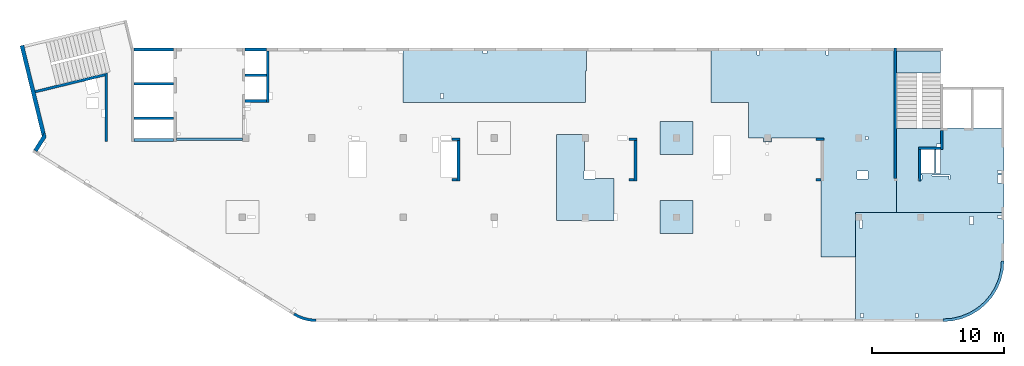
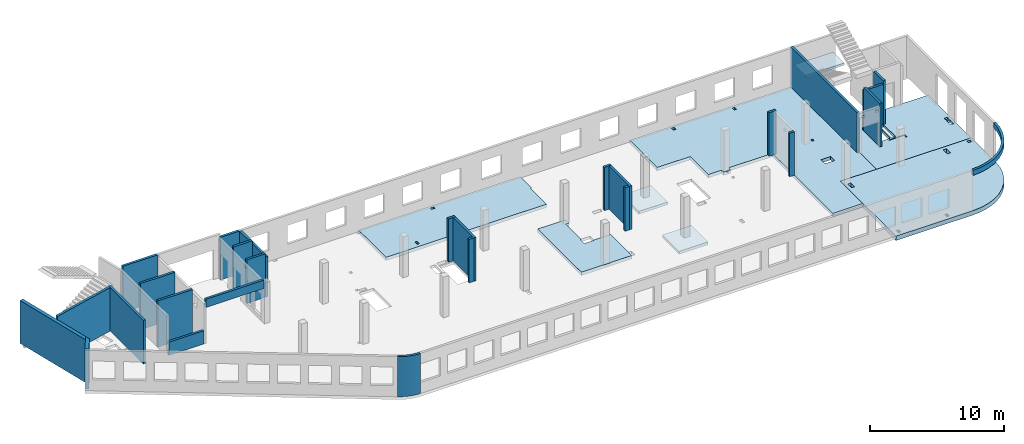
# One storey, part 2 of 6: 27 walls, 8 slabs.
"""IFC4 building model written with IfcOpenShell, lengths in millimetres."""

from ifc_helpers import new_model, entity, si_unit, converted_unit, derived_unit, direction, frame, origin, place, context, subcontext, project, spatial, indexed_curve, outline, extrude, material, type_object, element, save


model = new_model("IFC4")

# Units and contexts
model_context = context("Model", 3, precision=0.01, world=origin(), true_north=direction((6.12303176911189e-17, 1.0)))
plan_context = context("Plan", 3, precision=0.01, world=origin(), true_north=direction((6.12303176911189e-17, 1.0)))
body_context = subcontext(model_context, "Body", "Model", "MODEL_VIEW")
ifc_project = project(units=[si_unit("LENGTHUNIT", "METRE", prefix="MILLI"), si_unit("AREAUNIT", "SQUARE_METRE"), si_unit("VOLUMEUNIT", "CUBIC_METRE"), converted_unit("PLANEANGLEUNIT", "DEGREE", entity("IfcRatioMeasure", 0.0174532925199433), si_unit("PLANEANGLEUNIT", "RADIAN"), dimensions=[0, 0, 0, 0, 0, 0, 0]), si_unit("MASSUNIT", "GRAM", prefix="KILO"), derived_unit("MASSDENSITYUNIT", [(si_unit("MASSUNIT", "GRAM", prefix="KILO"), 1), (si_unit("LENGTHUNIT", "METRE"), -3)]), derived_unit("MOMENTOFINERTIAUNIT", [(si_unit("LENGTHUNIT", "METRE"), 4)]), si_unit("TIMEUNIT", "SECOND"), si_unit("FREQUENCYUNIT", "HERTZ"), si_unit("THERMODYNAMICTEMPERATUREUNIT", "DEGREE_CELSIUS"), derived_unit("THERMALTRANSMITTANCEUNIT", [(si_unit("MASSUNIT", "GRAM", prefix="KILO"), 1), (si_unit("THERMODYNAMICTEMPERATUREUNIT", "KELVIN"), -1), (si_unit("TIMEUNIT", "SECOND"), -3)]), derived_unit("VOLUMETRICFLOWRATEUNIT", [(si_unit("LENGTHUNIT", "METRE"), 3), (si_unit("TIMEUNIT", "SECOND"), -1)]), derived_unit("MASSFLOWRATEUNIT", [(si_unit("MASSUNIT", "GRAM", prefix="KILO"), 1), (si_unit("TIMEUNIT", "SECOND"), -1)]), derived_unit("ROTATIONALFREQUENCYUNIT", [(si_unit("TIMEUNIT", "SECOND"), -1)]), si_unit("ELECTRICCURRENTUNIT", "AMPERE"), si_unit("ELECTRICVOLTAGEUNIT", "VOLT"), si_unit("POWERUNIT", "WATT"), si_unit("FORCEUNIT", "NEWTON", prefix="KILO"), si_unit("ILLUMINANCEUNIT", "LUX"), si_unit("LUMINOUSFLUXUNIT", "LUMEN"), si_unit("LUMINOUSINTENSITYUNIT", "CANDELA"), derived_unit("USERDEFINED", [(si_unit("MASSUNIT", "GRAM", prefix="KILO"), -1), (si_unit("LENGTHUNIT", "METRE"), -2), (si_unit("TIMEUNIT", "SECOND"), 3), (si_unit("LUMINOUSFLUXUNIT", "LUMEN"), 1)]), derived_unit("LINEARVELOCITYUNIT", [(si_unit("LENGTHUNIT", "METRE"), 1), (si_unit("TIMEUNIT", "SECOND"), -1)]), si_unit("PRESSUREUNIT", "PASCAL"), derived_unit("USERDEFINED", [(si_unit("LENGTHUNIT", "METRE"), -2), (si_unit("MASSUNIT", "GRAM", prefix="KILO"), 1), (si_unit("TIMEUNIT", "SECOND"), -2)]), derived_unit("LINEARFORCEUNIT", [(si_unit("MASSUNIT", "GRAM", prefix="KILO"), 1), (si_unit("LENGTHUNIT", "METRE"), 1), (si_unit("TIMEUNIT", "SECOND"), -2), (si_unit("LENGTHUNIT", "METRE"), -1)]), derived_unit("PLANARFORCEUNIT", [(si_unit("MASSUNIT", "GRAM", prefix="KILO"), 1), (si_unit("LENGTHUNIT", "METRE"), 1), (si_unit("TIMEUNIT", "SECOND"), -2), (si_unit("LENGTHUNIT", "METRE"), -2)])], contexts=[model_context, plan_context])

# Site, building, storey
site_placement = place(None, origin())
site = spatial("IfcSite", under=ifc_project, at=site_placement, CompositionType="ELEMENT")
building_placement = place(site_placement, origin())
building = spatial("IfcBuilding", under=site, at=building_placement, CompositionType="ELEMENT")
storey_placement = place(building_placement, frame((0.0, 0.0, 8100.0)))
storey = spatial("IfcBuildingStorey", under=building, at=storey_placement, Name="03", CompositionType="ELEMENT", Elevation=8100.0)

# Slabs
ifc_material = material()
slab_type_1 = type_object("IfcSlabType", Name=":ADSK_ 25_300", PredefinedType="FLOOR", material=ifc_material)
placement = place(storey_placement, origin())
element("IfcSlab", 1, at=placement, inside=storey, type_object=slab_type_1, material=ifc_material, Name=":ADSK_ 25_300", ObjectType=":ADSK_ 25_300", PredefinedType="FLOOR", context=body_context, shape_type="SweptSolid", body=[
    extrude(outline(indexed_curve([(-6774.16666666654, -2197.29156649669), (-6774.16666666654, -2497.29156649652), (-6774.16666666654, -6097.29156649676), (-6774.16666666654, -6297.29156649672), (7265.83333333328, -6297.29156649672), (7265.83333333328, -6097.29156649676), (7265.83333333328, -3412.29188617987), (7265.83333333328, -2497.29156649651), (7265.83333333328, -527.291566496528), (7265.83333333329, 6152.70843350346), (4155.83333333329, 6152.70843350346), (4155.83333333329, 9502.70843350343), (1565.83333333329, 9502.70843350343), (1565.83333333328, 502.70843350344), (-2194.16666666669, 502.708433503438), (-2194.16666666669, 802.708433503275), (-2419.16666666676, 802.708433503273), (-2419.16666666676, 792.707391304612), (-2619.16666666675, 792.707391304612), (-2619.16666666675, 802.708433503274), (-2794.16666666671, 802.708433503274), (-2794.16666666671, 502.708433503384), (-3944.16666666658, 502.708433503383), (-3944.16666666658, -2197.29156649669), (-6774.16666666654, -2197.29156649669)], self_intersect=False), holes=[indexed_curve([(5105.83333333324, 402.707391304573), (4905.83333333325, 402.707391304574), (4905.83333333325, 602.707391304598), (5105.83333333324, 602.707391304597), (5105.83333333324, 402.707391304573)], self_intersect=False), indexed_curve([(4290.83333333324, 3017.70739130459), (4290.83333333324, 3617.70739130459), (5120.83333333326, 3617.70739130459), (5120.83333333326, 3017.70739130459), (4290.83333333324, 3017.70739130459)], self_intersect=False), indexed_curve([(2115.83333333324, -5797.29260869539), (2115.83333333324, -6097.29220586319), (1915.83333333322, -6097.29220586319), (1915.83333333322, -5797.29260869539), (2115.83333333324, -5797.29260869539)], self_intersect=False), indexed_curve([(-3094.16666666675, -5797.29260869538), (-3094.16666666675, -6097.29220586318), (-3294.16666666678, -6097.29220586318), (-3294.16666666678, -5797.29260869538), (-3094.16666666675, -5797.29260869538)], self_intersect=False)]), frame((58164.17, 14202.71, -450.0), z_axis=(0.0, 0.0, -1.0), x_axis=(1.0, 0.0, 0.0)), (0.0, 0.0, -1.0), 300.0),
])
slab_type_2 = type_object("IfcSlabType", Name=":ADSK_ 25_250", PredefinedType="FLOOR", material=ifc_material)
element("IfcSlab", 2, at=placement, inside=storey, type_object=slab_type_2, material=ifc_material, Name=":ADSK_ 25_250", ObjectType=":ADSK_ 25_250", PredefinedType="FLOOR", context=body_context, shape_type="SweptSolid", body=[
    extrude(outline(indexed_curve([(-3285.0, -2417.49999999997), (-3085.00000000002, -2417.49999999997), (1515.00000000001, -2417.49999999998), (1515.00000000001, -2377.50000000001), (4854.99999999999, -2377.50000000002), (4855.0, 4002.49999999997), (-3085.0, 4002.49999999999), (-3284.99999999999, 4002.49999999999), (-3285.0, -2417.49999999997)], self_intersect=False), holes=[indexed_curve([(-3084.99918212893, 1767.49895780109), (-2784.99999999999, 1767.49895780109), (-2784.99999999999, 1167.50000000054), (-3084.99918212893, 1167.50000000054), (-3084.99918212893, 1767.49895780109)], self_intersect=False), indexed_curve([(-3084.99918212893, 1002.49895780108), (-2784.99999999999, 1002.49895780108), (-2784.99999999999, 802.498957801087), (-3084.99918212893, 802.498957801087), (-3084.99918212893, 1002.49895780108)], self_intersect=False), indexed_curve([(1514.99999999996, -1177.50104219891), (1514.99999999996, -977.499999999505), (1815.00000000004, -977.499999999505), (1815.00000000004, -1177.50104219891), (1514.99999999996, -1177.50104219891)], self_intersect=False), indexed_curve([(3005.00000000001, 1487.49895780109), (3005.00000000001, 1147.49895780109), (2925.00000000003, 1147.49895780109), (2925.00000000003, 1487.49895780109), (3005.00000000001, 1487.49895780109)], self_intersect=False), indexed_curve([(3004.99999999993, 1027.49895780109), (3004.99999999993, -777.499999999511), (1965.00000000004, -777.499999999511), (1965.00000000004, 1027.49895780109), (3004.99999999993, 1027.49895780109)], self_intersect=False), indexed_curve([(1515.00000000004, 1027.49895780109), (1845.00000000003, 1027.49895780109), (1845.00000000003, -777.499999999505), (1515.00000000004, -777.499999999505), (1515.00000000004, 1027.49895780109)], self_intersect=False), indexed_curve([(885.000000000007, 1227.49895780108), (2185.00000000002, 1227.49895780108), (2185.00000000002, 1167.49895780109), (805.000000000025, 1167.49895780109), (805.000000000025, 1487.49895780109), (885.000000000007, 1487.49895780109), (885.000000000007, 1227.49895780108)], self_intersect=False)]), frame((70285.0, 12052.5, -400.0), z_axis=(0.0, 0.0, 1.0), x_axis=(-1.0, 0.0, 0.0)), (0.0, 0.0, 1.0), 249.999999999999),
])
slab_type_3 = type_object("IfcSlabType", Name=":ADSK_ 25_300", PredefinedType="FLOOR", material=ifc_material)
element("IfcSlab", 3, at=placement, inside=storey, type_object=slab_type_3, material=ifc_material, Name=":ADSK_ 25_300", ObjectType=":ADSK_ 25_300", PredefinedType="FLOOR", context=body_context, shape_type="SweptSolid", body=[
    extrude(outline(indexed_curve([(-1983.99983184359, -6920.0), (-1784.00047120995, -6920.0), (-1584.00087404217, -6920.0), (1816.00016815662, -6920.00000000001), (2116.00016815641, -6920.00000000001), (2116.00016815645, 6880.0), (1816.00016815666, 6880.0), (-263.999831843444, 6880.0), (-263.999831843444, 6980.0), (-1983.99983184354, 6980.0), (-1983.99983184359, -6920.0)], self_intersect=False), holes=[indexed_curve([(1455.99912595783, -3870.00000000006), (1815.99912595782, -3870.00000000006), (1815.99912595782, -4070.00000000005), (1455.99912595783, -4070.00000000005), (1455.99912595783, -3870.00000000006)], self_intersect=False), indexed_curve([(-1584.00087404217, -570.000000000044), (-1584.00087404217, -870.000000000045), (-1783.9998318435, -870.000000000045), (-1783.9998318435, -570.000000000044), (-1584.00087404217, -570.000000000044)], self_intersect=False)]), frame((34990.0, 18516.0, -450.0), z_axis=(0.0, 0.0, 1.0), x_axis=(0.0, -1.0, 0.0)), (0.0, 0.0, 1.0), 300.0),
])
slab_type_4 = type_object("IfcSlabType", Name=":ADSK_ 25_400", PredefinedType="FLOOR", material=ifc_material)
element("IfcSlab", 4, at=placement, inside=storey, type_object=slab_type_4, material=ifc_material, Name=":ADSK_ 25_400", ObjectType=":ADSK_ 25_400", PredefinedType="FLOOR", context=body_context, shape_type="SweptSolid", body=[
    extrude(outline(indexed_curve([(-3587.4999999999, -5067.08333333327), (-3287.49999999989, -5067.08333333327), (-512.500000000005, -5067.08333333327), (4462.49999999999, -5067.08333333328), (4662.49999999995, -5067.08333333328), (4662.49999999996, -4667.08333333327), (4662.49999999998, 1582.91666666618), (4605.86636673761, 2302.5152058513), (4437.35997495767, 3004.39484079108), (4161.13001126643, 3671.27296546831), (3783.97817412466, 4286.72882721185), (3315.19119345797, 4835.60786012465), (2766.31216054517, 5304.39484079136), (2150.85629880164, 5681.54667793313), (1483.97817412441, 5957.77664162439), (782.098539184638, 6126.28303340435), (62.4999999994953, 6182.91666666672), (-362.499999999969, 6182.91666666672), (-3587.49999999986, 6182.91666666673), (-3587.49999999986, 5982.91666666674), (-3587.49999999987, 3887.91666666673), (-3587.4999999999, -5067.08333333327)], self_intersect=False), holes=[indexed_curve([(4062.49895780123, -4467.08333333328), (4362.49895780123, -4467.08333333328), (4362.49895780123, -4666.87317969451), (4062.49895780123, -4666.87317969451), (4062.49895780123, -4467.08333333328)], self_intersect=False), indexed_curve([(4062.49895780123, -317.083333333292), (4362.49895780123, -317.083333333292), (4362.49895780123, -517.083333333281), (4062.49895780123, -517.083333333281), (4062.49895780123, -317.083333333292)], self_intersect=False), indexed_curve([(-2677.50104219876, 3887.91666666671), (-2677.50104219876, 3587.9166666667), (-3287.50104219876, 3587.9166666667), (-3287.50104219876, 3887.91666666671), (-2677.50104219876, 3887.91666666671)], self_intersect=False), indexed_curve([(-3362.50104219877, 5982.91584879566), (-3162.50104219878, 5982.91584879566), (-3162.50104219878, 5682.91666666673), (-3362.50104219877, 5682.91666666673), (-3362.50104219877, 5982.91584879566)], self_intersect=False), indexed_curve([(-2427.50104219875, -4767.08333333328), (-2987.49999999956, -4767.08333333328), (-2987.49999999956, -4567.08333333327), (-2987.49999999956, -4517.08333333327), (-2427.50104219875, -4517.08333333327), (-2427.50104219875, -4767.08333333328)], self_intersect=False)]), frame((67387.08, 4462.5, -550.0), z_axis=(0.0, 0.0, 1.0), x_axis=(0.0, -1.0, 0.0)), (0.0, 0.0, 1.0), 400.0),
])
slab_type_5 = type_object("IfcSlabType", Name=":ADSK_ 25_300", PredefinedType="FLOOR", material=ifc_material)
element("IfcSlab", 5, at=placement, inside=storey, type_object=slab_type_5, material=ifc_material, Name=":ADSK_ 25_300", ObjectType=":ADSK_ 25_300", PredefinedType="FLOOR", context=body_context, shape_type="SweptSolid", body=[
    extrude(outline(indexed_curve([(-3757.49999999989, -2308.33333333336), (2742.5000000001, -2308.33333333336), (2742.5000000001, 116.666666666688), (2242.49999999951, 116.666666666689), (2242.49999999951, -183.333333333312), (-22.4999999999042, -183.333333333309), (-22.4999999999043, -248.333333333355), (-622.499999999904, -248.333333333354), (-622.499999999905, 581.666666666648), (-582.499999999908, 581.666666666648), (-582.49999999991, 2041.66666666668), (-3757.4999999999, 2041.66666666669), (-3757.49999999989, -2308.33333333336)], self_intersect=False)), frame((42003.33, 11207.5, -150.0), z_axis=(0.0, 0.0, -1.0), x_axis=(0.0, 1.0, 0.0)), (0.0, 0.0, 1.0), 300.0),
])
slab_type_6 = type_object("IfcSlabType", Name=":ADSK_ 25_250", PredefinedType="FLOOR", material=ifc_material)
element("IfcSlab", 6, at=placement, inside=storey, type_object=slab_type_6, material=ifc_material, Name=":ADSK_ 25_250", ObjectType=":ADSK_ 25_250", PredefinedType="FLOOR", context=body_context, shape_type="SweptSolid", body=[
    extrude(outline(indexed_curve([(-1250.0, -1249.99999999999), (1250.0, -1249.99999999999), (1250.0, 1250.0), (-1250.0, 1250.0), (-1250.0, -1249.99999999999)], self_intersect=False)), frame((48770.0, 7700.0, -400.0), z_axis=(0.0, 0.0, -1.0), x_axis=(0.0, 1.0, 0.0)), (0.0, 0.0, 1.0), 250.000000000001),
])
slab_type_7 = type_object("IfcSlabType", Name=":ADSK_ 25_250", PredefinedType="FLOOR", material=ifc_material)
element("IfcSlab", 7, at=placement, inside=storey, type_object=slab_type_7, material=ifc_material, Name=":ADSK_ 25_250", ObjectType=":ADSK_ 25_250", PredefinedType="FLOOR", context=body_context, shape_type="SweptSolid", body=[
    extrude(outline(indexed_curve([(-1250.0, -1250.0), (1250.0, -1250.0), (1250.0, 1249.99999999999), (-1250.0, 1249.99999999999), (-1250.0, -1250.0)], self_intersect=False)), frame((48770.0, 13700.0, -400.0), z_axis=(0.0, 0.0, -1.0), x_axis=(0.0, 1.0, 0.0)), (0.0, 0.0, 1.0), 250.000000000001),
])
slab_type_8 = type_object("IfcSlabType", Name=":ADSK_ 25_200", PredefinedType="FLOOR", material=ifc_material)
element("IfcSlab", 8, at=placement, inside=storey, type_object=slab_type_8, material=ifc_material, Name=":ADSK_ 25_200", ObjectType=":ADSK_ 25_200", PredefinedType="FLOOR", context=body_context, shape_type="SweptSolid", body=[
    extrude(outline(indexed_curve([(-834.999999999999, -1670.00000000001), (835.000000000001, -1670.00000000001), (835.000000000001, 1670.00000000002), (-834.999999999999, 1670.00000000002), (-834.999999999999, -1670.00000000001)], self_intersect=False)), frame((67100.0, 19465.0, 1920.0), z_axis=(0.0, 0.0, -1.0), x_axis=(0.0, 1.0, 0.0)), (0.0, 0.0, 1.0), 200.0),
])

# Walls
wall_type_1 = type_object("IfcWallType", Name=":ADSK_ 25_200", PredefinedType="STANDARD")
wall_1_placement = place(storey_placement, frame((68870.0, 14270.0, -150.0), z_axis=(0.0, 0.0, 1.0), x_axis=(0.0, -1.0, 0.0)))
element("IfcWall", 9, at=wall_1_placement, inside=storey, type_object=wall_type_1, material=ifc_material, Name=":ADSK_ 25_200", ObjectType=":ADSK_ 25_200", PredefinedType="NOTDEFINED", context=body_context, shape_type="SweptSolid", body=[
    extrude(outline(indexed_curve([(1439.99999999999, 100.000000000003), (0.0, 100.000000000003), (0.0, -100.000000000003), (1439.99999999999, -100.000000000003), (1439.99999999999, 100.000000000003)], self_intersect=False)), origin(), (0.0, 0.0, 1.0), 3950.0),
])
wall_2_placement = place(storey_placement, frame((68770.0, 12930.0, -150.0), z_axis=(0.0, 0.0, 1.0), x_axis=(-1.0, 0.0, 0.0)))
element("IfcWall", 10, at=wall_2_placement, inside=storey, type_object=wall_type_1, material=ifc_material, Name=":ADSK_ 25_200", ObjectType=":ADSK_ 25_200", PredefinedType="NOTDEFINED", context=body_context, shape_type="SweptSolid", body=[
    extrude(outline(indexed_curve([(1689.99999999997, 99.9999999999989), (-3.84449868389964e-13, 99.9999999999989), (3.84449868389964e-13, -99.9999999999989), (1689.99999999997, -99.9999999999989), (1689.99999999997, 99.9999999999989)], self_intersect=False)), origin(), (0.0, 0.0, 1.0), 3650.0),
])
wall_3_placement = place(storey_placement, frame((67180.0, 12830.0, -150.0), z_axis=(0.0, 0.0, 1.0), x_axis=(0.0, -1.0, 0.0)))
element("IfcWall", 11, at=wall_3_placement, inside=storey, type_object=wall_type_1, material=ifc_material, Name=":ADSK_ 25_200", ObjectType=":ADSK_ 25_200", PredefinedType="NOTDEFINED", context=body_context, shape_type="SweptSolid", body=[
    extrude(outline(indexed_curve([(2404.99999999995, 100.000000000003), (0.0, 100.000000000003), (0.0, -100.000000000003), (2404.99999999995, -100.000000000003), (2404.99999999995, 100.000000000003)], self_intersect=False)), origin(), (0.0, 0.0, 1.0), 3950.0),
])
wall_4_placement = place(storey_placement, frame((65330.0, 10625.0, -150.0), z_axis=(0.0, 0.0, 1.0), x_axis=(0.0, 1.0, 0.0)))
element("IfcWall", 12, at=wall_4_placement, inside=storey, type_object=wall_type_1, material=ifc_material, Name=":ADSK_ 25_200", ObjectType=":ADSK_ 25_200", PredefinedType="NOTDEFINED", context=body_context, shape_type="SweptSolid", body=[
    extrude(outline(indexed_curve([(9875.00063936713, 100.000000000003), (-1.71685740578866e-13, 100.000000000003), (1.71685740578866e-13, -100.000000000003), (9875.00063936713, -100.000000000004), (9875.00063936713, 100.000000000003)], self_intersect=False)), origin(), (0.0, 0.0, 1.0), 3650.0),
])
wall_5_placement = place(storey_placement, frame((68970.0, -100.0, 3050.0)))
element("IfcWall", 13, at=wall_5_placement, inside=storey, type_object=wall_type_1, material=ifc_material, Name=":ADSK_ 25_200", ObjectType=":ADSK_ 25_200", PredefinedType="NOTDEFINED", context=body_context, shape_type="SweptSolid", body=[
    extrude(outline(indexed_curve([(4399.99918212903, 4499.99918212888), (4345.82789081698, 3811.68766389508), (4184.64789385715, 3140.32465961517), (3920.42797770043, 2502.44135458057), (3559.67411357824, 1913.74455277455), (3111.26925889869, 1388.72992323025), (2586.25462935438, 940.325068550716), (1997.55782754836, 579.571204428538), (1359.67452251375, 315.351288271842), (688.311518233829, 154.171291312031), (3.46517481375486e-11, 100.0), (0.0, -100.0), (719.598411241839, -43.3663768070014), (1421.47792138871, 125.139985012801), (2088.35592749623, 401.369899590849), (2703.81167981284, 778.521669675706), (3252.69061513597, 1247.30856699292), (3721.47751245321, 1796.18750231603), (4098.6292825381, 2411.64325463263), (4374.85919711618, 3078.52126074015), (4543.365558936, 3780.40077088701), (4599.99918212903, 4499.99918212885), (4399.99918212903, 4499.99918212888)], self_intersect=False)), origin(), (0.0, 0.0, 1.0), 450.000000000002),
])
wall_6_placement = place(storey_placement, frame((19822.35, 371.16, -150.0)))
element("IfcWall", 14, at=wall_6_placement, inside=storey, type_object=wall_type_1, material=ifc_material, Name=":ADSK_ 25_200", ObjectType=":ADSK_ 25_200", PredefinedType="NOTDEFINED", context=body_context, shape_type="SweptSolid", body=[
    extrude(outline(indexed_curve([(1647.48298908956, -371.159642137684), (1479.53495854193, -366.732336838998), (1312.09852486252, -352.905454552832), (1145.69934172072, -329.72240370142), (980.859806418502, -297.255965670987), (818.09741986465, -255.608066320247), (657.923161920899, -204.909455992096), (500.839887220395, -145.319299033065), (347.340746494629, -77.024674109233), (197.907638365059, -0.239986887291593), (53.0096964598414, 84.7937030753815), (-53.0096964598197, -84.7937030753918), (101.553010904459, -175.499182842681), (260.953382356765, -257.405447245706), (424.69099282044, -330.255357933605), (592.251800794088, -393.820208274097), (763.109762144871, -447.900441360165), (936.728481583211, -492.326276503471), (1112.5628966341, -526.958242247616), (1290.06098881835, -551.687614227945), (1468.66551667174, -566.436756503237), (1647.81576516126, -571.159365287708), (1647.48298908956, -371.159642137684)], self_intersect=False)), origin(), (0.0, 0.0, 1.0), 3650.0),
])
wall_7_placement = place(storey_placement, frame((17825.0, 20300.0, -150.0), z_axis=(0.0, 0.0, 1.0), x_axis=(0.0, -1.0, 0.0)))
element("IfcWall", 15, at=wall_7_placement, inside=storey, type_object=wall_type_1, material=ifc_material, Name=":ADSK_ 25_200", ObjectType=":ADSK_ 25_200", PredefinedType="NOTDEFINED", context=body_context, shape_type="SweptSolid", body=[
    extrude(outline(indexed_curve([(3900.00063936684, 99.9999999999989), (-1.66594915657375e-13, 99.9999999999989), (1.66594915657375e-13, -99.9999999999989), (3900.00063936684, -99.9999999999989), (3900.00063936684, 99.9999999999989)], self_intersect=False)), origin(), (0.0, 0.0, 1.0), 3650.0),
])
wall_8_placement = place(storey_placement, frame((17725.0, 16500.0, -150.0), z_axis=(0.0, 0.0, 1.0), x_axis=(-1.0, 0.0, 0.0)))
element("IfcWall", 16, at=wall_8_placement, inside=storey, type_object=wall_type_1, material=ifc_material, Name=":ADSK_ 25_200", ObjectType=":ADSK_ 25_200", PredefinedType="NOTDEFINED", context=body_context, shape_type="SweptSolid", body=[
    extrude(outline(indexed_curve([(1624.99999999999, 99.9999999999982), (-3.56011111002209e-13, 99.9999999999989), (3.56011111002209e-13, -99.9999999999989), (1624.99999999999, -99.9999999999996), (1624.99999999999, 99.9999999999982)], self_intersect=False)), origin(), (0.0, 0.0, 1.0), 3950.0),
])
wall_9_placement = place(storey_placement, frame((5600.0, 13450.0, -150.0), z_axis=(0.0, 0.0, 1.0), x_axis=(0.0, 1.0, 0.0)))
element("IfcWall", 17, at=wall_9_placement, inside=storey, type_object=wall_type_1, material=ifc_material, Name=":ADSK_ 25_200", ObjectType=":ADSK_ 25_200", PredefinedType="NOTDEFINED", context=body_context, shape_type="SweptSolid", body=[
    extrude(outline(indexed_curve([(5191.05764338749, -100.0), (5142.30552742916, 99.9999999999995), (4936.44934265344, 100.0), (-1.37676332088153e-13, 100.0), (1.37676332088153e-13, -100.0), (5191.05764338749, -100.0)], self_intersect=False)), origin(), (0.0, 0.0, 1.0), 3950.0),
])
wall_10_placement = place(storey_placement, frame((220.24, 17202.38, -150.0), z_axis=(0.0, 0.0, 1.0), x_axis=(0.971552058141472, 0.236826092990341, 0.0)))
element("IfcWall", 18, at=wall_10_placement, inside=storey, type_object=wall_type_1, material=ifc_material, Name=":ADSK_ 25_200", ObjectType=":ADSK_ 25_200", PredefinedType="NOTDEFINED", context=body_context, shape_type="SweptSolid", body=[
    extrude(outline(indexed_curve([(5409.98499256816, -100.000000000001), (5458.73710852649, 99.9999999999987), (-1.22668541990834e-13, 100.0), (1.17592602322247e-12, -100.0), (5409.98499256816, -100.000000000001)], self_intersect=False)), origin(), (0.0, 0.0, 1.0), 3950.0),
])
wall_11_placement = place(storey_placement, frame((16100.0, 20400.0, -400.0)))
element("IfcWall", 19, at=wall_11_placement, inside=storey, type_object=wall_type_1, material=ifc_material, Name=":ADSK_ 25_200", ObjectType=":ADSK_ 25_200", PredefinedType="NOTDEFINED", context=body_context, shape_type="SweptSolid", body=[
    extrude(outline(indexed_curve([(1624.99999999999, 99.9999999999989), (-2.66551908750372e-13, 99.9999999999989), (2.66551908750372e-13, -99.9999999999989), (1624.99999999999, -99.9999999999989), (1624.99999999999, 99.9999999999989)], self_intersect=False)), origin(), (0.0, 0.0, 1.0), 3900.0),
])
wall_12_placement = place(storey_placement, frame((16100.0, 18450.0, -400.0)))
element("IfcWall", 20, at=wall_12_placement, inside=storey, type_object=wall_type_1, material=ifc_material, Name=":ADSK_ 25_200", ObjectType=":ADSK_ 25_200", PredefinedType="NOTDEFINED", context=body_context, shape_type="SweptSolid", body=[
    extrude(outline(indexed_curve([(1624.99999999999, 99.9999999999989), (-2.66551908750371e-13, 99.9999999999989), (2.66551908750371e-13, -99.9999999999989), (1624.99999999999, -99.9999999999989), (1624.99999999999, 99.9999999999989)], self_intersect=False)), origin(), (0.0, 0.0, 1.0), 4200.0),
])
wall_13_placement = place(storey_placement, frame((7500.0, 20400.0, -400.0)))
element("IfcWall", 21, at=wall_13_placement, inside=storey, type_object=wall_type_1, material=ifc_material, Name=":ADSK_ 25_200", ObjectType=":ADSK_ 25_200", PredefinedType="NOTDEFINED", context=body_context, shape_type="SweptSolid", body=[
    extrude(outline(indexed_curve([(3200.0, -100.000000000003), (3200.0, 99.9999999999995), (200.0, 99.9999999999995), (200.0, -100.000000000003), (3200.0, -100.000000000003)], self_intersect=False)), origin(), (0.0, 0.0, 1.0), 4200.0),
])
for number, where, name in (
    (22, (7700.0, 17800.0, -400.0), ":ADSK_ 25_200"),
    (23, (7700.0, 15200.0, -400.0), ":ADSK_ 25_200"),
):
    element("IfcWall", number, at=place(storey_placement, frame(where)), inside=storey, type_object=wall_type_1, material=ifc_material, Name=name, ObjectType=":ADSK_ 25_200", PredefinedType="NOTDEFINED", context=body_context, shape_type="SweptSolid", body=[
        extrude(outline(indexed_curve([(3000.0, 99.9999999999989), (-2.88764567812902e-13, 99.9999999999989), (2.88764567812902e-13, -99.9999999999989), (3000.0, -99.9999999999989), (3000.0, 99.9999999999989)], self_intersect=False)), origin(), (0.0, 0.0, 1.0), 4200.0),
    ])
wall_14_placement = place(storey_placement, frame((59330.0, 13600.0, -150.0)))
element("IfcWall", 24, at=wall_14_placement, inside=storey, type_object=wall_type_1, material=ifc_material, Name=":ADSK_ 25_200", ObjectType=":ADSK_ 25_200", PredefinedType="NOTDEFINED", context=body_context, shape_type="SweptSolid", body=[
    extrude(outline(indexed_curve([(599.999999999993, 99.9999999999989), (-3.60955709766131e-13, 99.9999999999989), (3.60955709766131e-13, -99.9999999999989), (599.999999999994, -99.9999999999989), (599.999999999993, 99.9999999999989)], self_intersect=False)), origin(), (0.0, 0.0, 1.0), 3950.0),
])
wall_15_placement = place(storey_placement, frame((59730.0, 10525.0, -150.0), z_axis=(0.0, 0.0, 1.0), x_axis=(-1.0, 0.0, 0.0)))
element("IfcWall", 25, at=wall_15_placement, inside=storey, type_object=wall_type_1, material=ifc_material, Name=":ADSK_ 25_200", ObjectType=":ADSK_ 25_200", PredefinedType="NOTDEFINED", context=body_context, shape_type="SweptSolid", body=[
    extrude(outline(indexed_curve([(399.999999999987, 99.9999999999982), (-3.60955709766136e-13, 99.9999999999989), (3.60955709766136e-13, -99.9999999999989), (399.999999999987, -99.9999999999996), (399.999999999987, 99.9999999999982)], self_intersect=False)), origin(), (0.0, 0.0, 1.0), 3950.0),
])
wall_16_placement = place(storey_placement, frame((45170.0, 13600.0, -150.0)))
element("IfcWall", 26, at=wall_16_placement, inside=storey, type_object=wall_type_1, material=ifc_material, Name=":ADSK_ 25_200", ObjectType=":ADSK_ 25_200", PredefinedType="NOTDEFINED", context=body_context, shape_type="SweptSolid", body=[
    extrude(outline(indexed_curve([(599.999999999993, 99.9999999999989), (-3.60955709766131e-13, 99.9999999999989), (3.60955709766131e-13, -99.9999999999989), (599.999999999994, -99.9999999999989), (599.999999999993, 99.9999999999989)], self_intersect=False)), origin(), (0.0, 0.0, 1.0), 3950.0),
])
wall_17_placement = place(storey_placement, frame((45670.0, 13500.0, -150.0), z_axis=(0.0, 0.0, 1.0), x_axis=(0.0, -1.0, 0.0)))
element("IfcWall", 27, at=wall_17_placement, inside=storey, type_object=wall_type_1, material=ifc_material, Name=":ADSK_ 25_200", ObjectType=":ADSK_ 25_200", PredefinedType="NOTDEFINED", context=body_context, shape_type="SweptSolid", body=[
    extrude(outline(indexed_curve([(3074.99985044015, 100.000000000003), (-2.64517173435081e-13, 100.000000000003), (2.64517173435081e-13, -100.000000000003), (3074.99985044015, -100.000000000004), (3074.99985044015, 100.000000000003)], self_intersect=False)), origin(), (0.0, 0.0, 1.0), 3950.0),
])
wall_18_placement = place(storey_placement, frame((45570.0, 10525.0, -150.0), z_axis=(0.0, 0.0, 1.0), x_axis=(-1.0, 0.0, 0.0)))
element("IfcWall", 28, at=wall_18_placement, inside=storey, type_object=wall_type_1, material=ifc_material, Name=":ADSK_ 25_200", ObjectType=":ADSK_ 25_200", PredefinedType="NOTDEFINED", context=body_context, shape_type="SweptSolid", body=[
    extrude(outline(indexed_curve([(399.999999999995, 99.9999999999982), (-3.60955709766131e-13, 99.9999999999989), (3.60955709766131e-13, -99.9999999999989), (399.999999999996, -99.9999999999996), (399.999999999995, 99.9999999999982)], self_intersect=False)), origin(), (0.0, 0.0, 1.0), 3950.0),
])
wall_19_placement = place(storey_placement, frame((31770.0, 13600.0, -150.0)))
element("IfcWall", 29, at=wall_19_placement, inside=storey, type_object=wall_type_1, material=ifc_material, Name=":ADSK_ 25_200", ObjectType=":ADSK_ 25_200", PredefinedType="NOTDEFINED", context=body_context, shape_type="SweptSolid", body=[
    extrude(outline(indexed_curve([(600.000000000002, 99.9999999999989), (-3.60955709766126e-13, 99.9999999999989), (3.60955709766126e-13, -99.9999999999989), (600.000000000003, -99.9999999999989), (600.000000000002, 99.9999999999989)], self_intersect=False)), origin(), (0.0, 0.0, 1.0), 3950.0),
])
wall_20_placement = place(storey_placement, frame((32270.0, 13500.0, -150.0), z_axis=(0.0, 0.0, 1.0), x_axis=(0.0, -1.0, 0.0)))
element("IfcWall", 30, at=wall_20_placement, inside=storey, type_object=wall_type_1, material=ifc_material, Name=":ADSK_ 25_200", ObjectType=":ADSK_ 25_200", PredefinedType="NOTDEFINED", context=body_context, shape_type="SweptSolid", body=[
    extrude(outline(indexed_curve([(3074.99985044025, 99.9999999999987), (-1.32258586717531e-13, 99.9999999999989), (1.32258586717531e-13, -99.9999999999989), (3074.99985044025, -99.9999999999992), (3074.99985044025, 99.9999999999987)], self_intersect=False)), origin(), (0.0, 0.0, 1.0), 3950.0),
])
wall_21_placement = place(storey_placement, frame((32170.0, 10525.0, -150.0), z_axis=(0.0, 0.0, 1.0), x_axis=(-1.0, 0.0, 0.0)))
element("IfcWall", 31, at=wall_21_placement, inside=storey, type_object=wall_type_1, material=ifc_material, Name=":ADSK_ 25_200", ObjectType=":ADSK_ 25_200", PredefinedType="NOTDEFINED", context=body_context, shape_type="SweptSolid", body=[
    extrude(outline(indexed_curve([(399.999999999995, 99.9999999999982), (-3.60955709766131e-13, 99.9999999999989), (3.60955709766131e-13, -99.9999999999989), (399.999999999996, -99.9999999999996), (399.999999999995, 99.9999999999982)], self_intersect=False)), origin(), (0.0, 0.0, 1.0), 3950.0),
])
wall_22_placement = place(storey_placement, frame((10900.0, 13600.0, 3050.0)))
element("IfcWall", 32, at=wall_22_placement, inside=storey, type_object=wall_type_1, material=ifc_material, Name=":ADSK_ 25_200", ObjectType=":ADSK_ 25_200", PredefinedType="NOTDEFINED", context=body_context, shape_type="SweptSolid", body=[
    extrude(outline(indexed_curve([(4999.99925537109, 99.9999999999989), (-3.03202841358267e-13, 99.9999999999989), (3.03202841358267e-13, -99.9999999999989), (4999.99925537109, -99.9999999999989), (4999.99925537109, 99.9999999999989)], self_intersect=False)), origin(), (0.0, 0.0, 1.0), 749.999999999998),
])
wall_23_placement = place(storey_placement, frame((7700.0, 13550.0, -150.0)))
element("IfcWall", 33, at=wall_23_placement, inside=storey, type_object=wall_type_1, material=ifc_material, Name=":ADSK_ 25_200", ObjectType=":ADSK_ 25_200", PredefinedType="NOTDEFINED", context=body_context, shape_type="SweptSolid", body=[
    extrude(outline(indexed_curve([(3000.0, 99.9999999999989), (-2.88764567812902e-13, 99.9999999999989), (2.88764567812902e-13, -99.9999999999989), (3000.0, -99.9999999999989), (3000.0, 99.9999999999989)], self_intersect=False)), origin(), (0.0, 0.0, 1.0), 1200.0),
])
wall_type_2 = type_object("IfcWallType", Name=":ADSK_ 25_300", PredefinedType="STANDARD")
wall_24_placement = place(storey_placement, frame((233.05, 12729.59, -150.0), z_axis=(0.0, 0.0, 1.0), x_axis=(0.529911826412024, 0.848052743777575, 0.0)))
element("IfcWall", 34, at=wall_24_placement, inside=storey, type_object=wall_type_2, material=ifc_material, Name=":ADSK_ 25_300", ObjectType=":ADSK_ 25_300", PredefinedType="NOTDEFINED", context=body_context, shape_type="SweptSolid", body=[
    extrude(outline(indexed_curve([(1316.31557757947, -150.0), (1609.08571844498, 150.0), (1189.90275674163, 150.000000000001), (2.08113526412035e-12, 150.0), (9.05209240897875e-13, -150.0), (100.258465181471, -150.0), (900.258465181472, -150.0), (1316.31557757947, -150.0)], self_intersect=False)), origin(), (0.0, 0.0, 1.0), 3650.0),
])
wall_25_placement = place(storey_placement, frame((-787.54, 20703.3, -400.0), z_axis=(0.0, 0.0, 1.0), x_axis=(0.236826092990339, -0.971552058141473, 0.0)))
element("IfcWall", 35, at=wall_25_placement, inside=storey, type_object=wall_type_2, material=ifc_material, Name=":ADSK_ 25_300", ObjectType=":ADSK_ 25_300", PredefinedType="NOTDEFINED", context=body_context, shape_type="SweptSolid", body=[
    extrude(outline(indexed_curve([(7050.16407046696, -150.0), (6757.39392960146, 150.0), (-2.19957385638736e-13, 150.0), (1.86117787848161e-13, -150.0), (7050.16407046696, -150.0)], self_intersect=False)), origin(), (0.0, 0.0, 1.0), 3900.0),
])

save(model, "model.ifc")
